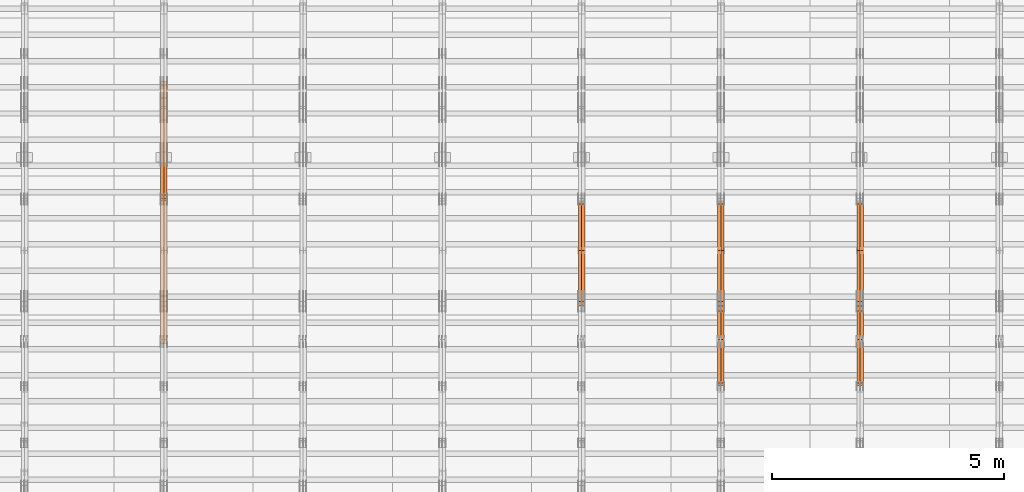
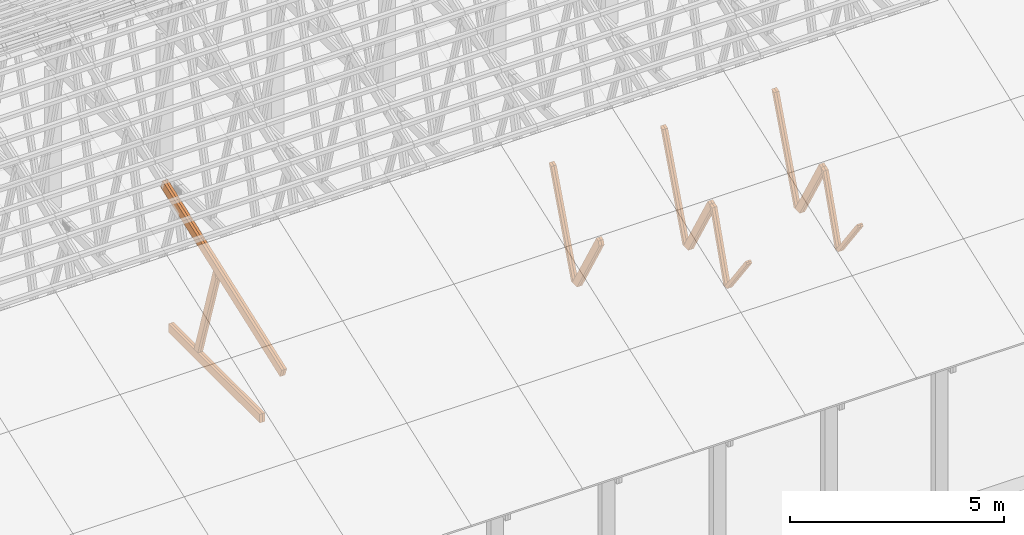
# One storey, part 24 of 189: 26 proxies.
"""IFC2X3 building model written with IfcOpenShell, lengths in millimetres."""

from ifc_helpers import new_model, entity, si_unit, converted_unit, derived_unit, direction, frame, origin, origin_2d_with_axis, place, context, subcontext, project, spatial, polyline, rectangle, outline, extrude, source, transform, mapped, material, type_object, type_shapes, element, save


model = new_model("IFC2X3")

# Units and contexts
model_context = context("Model", 3, precision=0.01, world=origin(), true_north=direction((6.12303176911189e-17, 1.0)))
body_context = subcontext(model_context, "Body", "Model", "MODEL_VIEW")
ifc_project = project(units=[si_unit("LENGTHUNIT", "METRE", prefix="MILLI"), si_unit("AREAUNIT", "SQUARE_METRE"), si_unit("VOLUMEUNIT", "CUBIC_METRE"), converted_unit("PLANEANGLEUNIT", "DEGREE", entity("IfcRatioMeasure", 0.0174532925199433), si_unit("PLANEANGLEUNIT", "RADIAN"), dimensions=[0, 0, 0, 0, 0, 0, 0]), si_unit("MASSUNIT", "GRAM", prefix="KILO"), derived_unit("MASSDENSITYUNIT", [(si_unit("MASSUNIT", "GRAM", prefix="KILO"), 1), (si_unit("LENGTHUNIT", "METRE"), -3)]), si_unit("TIMEUNIT", "SECOND"), si_unit("FREQUENCYUNIT", "HERTZ"), si_unit("THERMODYNAMICTEMPERATUREUNIT", "DEGREE_CELSIUS"), derived_unit("THERMALTRANSMITTANCEUNIT", [(si_unit("MASSUNIT", "GRAM", prefix="KILO"), 1), (si_unit("THERMODYNAMICTEMPERATUREUNIT", "KELVIN"), -1), (si_unit("TIMEUNIT", "SECOND"), -3)]), derived_unit("VOLUMETRICFLOWRATEUNIT", [(si_unit("LENGTHUNIT", "METRE"), 3), (si_unit("TIMEUNIT", "SECOND"), -1)]), si_unit("ELECTRICCURRENTUNIT", "AMPERE"), si_unit("ELECTRICVOLTAGEUNIT", "VOLT"), si_unit("POWERUNIT", "WATT"), si_unit("FORCEUNIT", "NEWTON"), si_unit("ILLUMINANCEUNIT", "LUX"), si_unit("LUMINOUSFLUXUNIT", "LUMEN"), si_unit("LUMINOUSINTENSITYUNIT", "CANDELA"), derived_unit("USERDEFINED", [(si_unit("MASSUNIT", "GRAM", prefix="KILO"), -1), (si_unit("LENGTHUNIT", "METRE"), -2), (si_unit("TIMEUNIT", "SECOND"), 3), (si_unit("LUMINOUSFLUXUNIT", "LUMEN"), 1)]), derived_unit("LINEARVELOCITYUNIT", [(si_unit("LENGTHUNIT", "METRE"), 1), (si_unit("TIMEUNIT", "SECOND"), -1)]), si_unit("PRESSUREUNIT", "PASCAL"), derived_unit("USERDEFINED", [(si_unit("LENGTHUNIT", "METRE"), -2), (si_unit("MASSUNIT", "GRAM", prefix="KILO"), 1), (si_unit("TIMEUNIT", "SECOND"), -2)])], contexts=[model_context])

# Site, building, storey
site_placement = place(None, origin())
site = spatial("IfcSite", under=ifc_project, at=site_placement, CompositionType="ELEMENT")
building_placement = place(site_placement, origin())
building = spatial("IfcBuilding", under=site, at=building_placement, CompositionType="ELEMENT")
storey_placement = place(building_placement, origin())
storey = spatial("IfcBuildingStorey", under=building, at=storey_placement, Name="Default", CompositionType="ELEMENT", Elevation=0.0)

# Proxies
ifc_material_1 = material(Name="IfcSurfaceStyle #161790")
building_element_proxy_type_1 = type_object("IfcBuildingElementProxyType", Name="T1-W8 161788", PredefinedType="NOTDEFINED", material=ifc_material_1)
shared_shape_1 = source(origin(), body_context, "Body", "SweptSolid", [
    extrude(outline(polyline([(-1781.70529904483, -47.500320228718), (1161.65050357787, -47.5003202287179), (1179.56135870849, 0.000731866266039397), (1140.6022069428, 47.4998218997103), (-1700.10877018433, 47.5000866914596), (-1781.70529904483, -47.500320228718)])), frame((1179.56135870869, 47.5007236522113, 0.0), z_axis=(0.0, 0.0, 1.0), x_axis=(-1.0, 3.74658825645258e-07, 0.0)), (0.0, 0.0, 1.0), 69.9999999999998),
])
type_shapes(building_element_proxy_type_1, [shared_shape_1])
proxy_1_placement = place(building_placement, frame((30300.0, 6723.5697965901, 261.758864533503), z_axis=(-1.0, 0.0, 0.0), x_axis=(0.0, 0.352814979177603, 0.93569310698963)))
element("IfcBuildingElementProxy", 1, at=proxy_1_placement, inside=storey, type_object=building_element_proxy_type_1, material=ifc_material_1, Name="T1-W8", context=body_context, shape_type="MappedRepresentation", body=[
    mapped(shared_shape_1, transform((0.0, 0.0, 0.0), scale=1.0)),
])
ifc_material_2 = material(Name="IfcSurfaceStyle #161724")
building_element_proxy_type_2 = type_object("IfcBuildingElementProxyType", Name="T1-W8 161722", PredefinedType="NOTDEFINED", material=ifc_material_2)
shared_shape_2 = source(origin(), body_context, "Body", "SweptSolid", [
    extrude(outline(polyline([(-1781.70529904483, -47.500320228718), (1161.65050357787, -47.5003202287179), (1179.56135870849, 0.000731866266039397), (1140.6022069428, 47.4998218997103), (-1700.10877018433, 47.5000866914596), (-1781.70529904483, -47.500320228718)])), frame((1179.56135870869, 47.5007236522113, 0.0), z_axis=(0.0, 0.0, 1.0), x_axis=(-1.0, 3.74658825645258e-07, 0.0)), (0.0, 0.0, 1.0), 69.9999999999998),
])
type_shapes(building_element_proxy_type_2, [shared_shape_2])
proxy_2_placement = place(building_placement, frame((30230.0, 6723.5697965901, 261.758864533503), z_axis=(-1.0, 0.0, 0.0), x_axis=(0.0, 0.352814979177603, 0.93569310698963)))
element("IfcBuildingElementProxy", 2, at=proxy_2_placement, inside=storey, type_object=building_element_proxy_type_2, material=ifc_material_2, Name="T1-W8", context=body_context, shape_type="MappedRepresentation", body=[
    mapped(shared_shape_2, transform((0.0, 0.0, 0.0), scale=1.0)),
])
ifc_material_3 = material(Name="IfcSurfaceStyle #161526")
building_element_proxy_type_3 = type_object("IfcBuildingElementProxyType", Name="T1-W2 161524", PredefinedType="NOTDEFINED", material=ifc_material_3)
shared_shape_3 = source(origin(), body_context, "Body", "SweptSolid", [
    extrude(outline(polyline([(-765.033104991319, -1130.91940266317), (-539.905732758898, -1130.91940266317), (493.678280567457, 660.584515081422), (452.144945212405, 783.697385511457), (359.115611970356, 817.556904733455), (-765.033104991319, -1130.91940266317)])), frame((904.774360566371, 97.5002668805543, 0.0), z_axis=(0.0, 0.0, 1.0), x_axis=(-0.499731715721184, 0.866180242387438, 0.0)), (0.0, 0.0, 1.0), 69.9999999999998),
])
type_shapes(building_element_proxy_type_3, [shared_shape_3])
proxy_3_placement = place(building_placement, frame((30300.0, 5635.28919163287, 2208.3400784451), z_axis=(-1.0, 0.0, 0.0), x_axis=(0.0, 0.5, -0.866025403784439)))
element("IfcBuildingElementProxy", 3, at=proxy_3_placement, inside=storey, type_object=building_element_proxy_type_3, material=ifc_material_3, Name="T1-W2", context=body_context, shape_type="MappedRepresentation", body=[
    mapped(shared_shape_3, transform((0.0, 0.0, 0.0), scale=1.0)),
])
ifc_material_4 = material(Name="IfcSurfaceStyle #161460")
building_element_proxy_type_4 = type_object("IfcBuildingElementProxyType", Name="T1-W2 161458", PredefinedType="NOTDEFINED", material=ifc_material_4)
shared_shape_4 = source(origin(), body_context, "Body", "SweptSolid", [
    extrude(outline(polyline([(-765.033104991319, -1130.91940266317), (-539.905732758898, -1130.91940266317), (493.678280567457, 660.584515081422), (452.144945212405, 783.697385511457), (359.115611970356, 817.556904733455), (-765.033104991319, -1130.91940266317)])), frame((904.774360566371, 97.5002668805543, 0.0), z_axis=(0.0, 0.0, 1.0), x_axis=(-0.499731715721184, 0.866180242387438, 0.0)), (0.0, 0.0, 1.0), 69.9999999999998),
])
type_shapes(building_element_proxy_type_4, [shared_shape_4])
proxy_4_placement = place(building_placement, frame((30230.0, 5635.28919163287, 2208.3400784451), z_axis=(-1.0, 0.0, 0.0), x_axis=(0.0, 0.5, -0.866025403784439)))
element("IfcBuildingElementProxy", 4, at=proxy_4_placement, inside=storey, type_object=building_element_proxy_type_4, material=ifc_material_4, Name="T1-W2", context=body_context, shape_type="MappedRepresentation", body=[
    mapped(shared_shape_4, transform((0.0, 0.0, 0.0), scale=1.0)),
])
ifc_material_5 = material(Name="IfcSurfaceStyle #161262")
building_element_proxy_type_5 = type_object("IfcBuildingElementProxyType", Name="T1-W9 161260", PredefinedType="NOTDEFINED", material=ifc_material_5)
shared_shape_5 = source(origin(), body_context, "Body", "SweptSolid", [
    extrude(outline(polyline([(-1227.3969292634, -47.5000382896404), (793.242467803064, -47.5000382896404), (809.267705296822, 1.0956605530188e-05), (776.329919980315, 47.5000328113376), (-1151.4431638168, 47.5000328113376), (-1227.3969292634, -47.5000382896404)])), frame((809.267705296822, 47.5000328113376, 0.0), z_axis=(0.0, 0.0, 1.0), x_axis=(-1.0, 0.0, 0.0)), (0.0, 0.0, 1.0), 69.9999999999999),
])
type_shapes(building_element_proxy_type_5, [shared_shape_5])
proxy_5_placement = place(building_placement, frame((30300.0, 4809.76380889125, 260.184242613649), z_axis=(-1.0, 0.0, 0.0), x_axis=(0.0, 0.31966811847134, 0.947529574226047)))
element("IfcBuildingElementProxy", 5, at=proxy_5_placement, inside=storey, type_object=building_element_proxy_type_5, material=ifc_material_5, Name="T1-W9", context=body_context, shape_type="MappedRepresentation", body=[
    mapped(shared_shape_5, transform((0.0, 0.0, 0.0), scale=1.0)),
])
ifc_material_6 = material(Name="IfcSurfaceStyle #161196")
building_element_proxy_type_6 = type_object("IfcBuildingElementProxyType", Name="T1-W9 161194", PredefinedType="NOTDEFINED", material=ifc_material_6)
shared_shape_6 = source(origin(), body_context, "Body", "SweptSolid", [
    extrude(outline(polyline([(-1227.3969292634, -47.5000382896404), (793.242467803064, -47.5000382896404), (809.267705296822, 1.0956605530188e-05), (776.329919980315, 47.5000328113376), (-1151.4431638168, 47.5000328113376), (-1227.3969292634, -47.5000382896404)])), frame((809.267705296822, 47.5000328113376, 0.0), z_axis=(0.0, 0.0, 1.0), x_axis=(-1.0, 0.0, 0.0)), (0.0, 0.0, 1.0), 69.9999999999999),
])
type_shapes(building_element_proxy_type_6, [shared_shape_6])
proxy_6_placement = place(building_placement, frame((30230.0, 4809.76380889125, 260.184242613649), z_axis=(-1.0, 0.0, 0.0), x_axis=(0.0, 0.31966811847134, 0.947529574226047)))
element("IfcBuildingElementProxy", 6, at=proxy_6_placement, inside=storey, type_object=building_element_proxy_type_6, material=ifc_material_6, Name="T1-W9", context=body_context, shape_type="MappedRepresentation", body=[
    mapped(shared_shape_6, transform((0.0, 0.0, 0.0), scale=1.0)),
])
ifc_material_7 = material(Name="IfcSurfaceStyle #160998")
building_element_proxy_type_7 = type_object("IfcBuildingElementProxyType", Name="T1-W10 160996", PredefinedType="NOTDEFINED", material=ifc_material_7)
shared_shape_7 = source(origin(), body_context, "Body", "SweptSolid", [
    extrude(outline(polyline([(-922.639472665691, -47.5001890573134), (629.920966338637, -47.5001890573134), (650.067737483374, 0.000694680531158376), (635.89112756682, 47.4998417170478), (-993.240358723139, 47.4998417170478), (-922.639472665691, -47.5001890573134)])), frame((650.068202545693, 47.4999816623145, 0.0), z_axis=(0.0, 0.0, 1.0), x_axis=(-1.0, 0.0, 0.0)), (0.0, 0.0, 1.0), 69.9999999999999),
])
type_shapes(building_element_proxy_type_7, [shared_shape_7])
proxy_7_placement = place(building_placement, frame((30300.0, 3874.56126239818, 1563.95828147518), z_axis=(-1.0, 0.0, 0.0), x_axis=(0.0, 0.596486092002, -0.802623412347398)))
element("IfcBuildingElementProxy", 7, at=proxy_7_placement, inside=storey, type_object=building_element_proxy_type_7, material=ifc_material_7, Name="T1-W10", context=body_context, shape_type="MappedRepresentation", body=[
    mapped(shared_shape_7, transform((0.0, 0.0, 0.0), scale=1.0)),
])
ifc_material_8 = material(Name="IfcSurfaceStyle #160932")
building_element_proxy_type_8 = type_object("IfcBuildingElementProxyType", Name="T1-W10 160930", PredefinedType="NOTDEFINED", material=ifc_material_8)
shared_shape_8 = source(origin(), body_context, "Body", "SweptSolid", [
    extrude(outline(polyline([(-922.639472665691, -47.5001890573134), (629.920966338637, -47.5001890573134), (650.067737483374, 0.000694680531158376), (635.89112756682, 47.4998417170478), (-993.240358723139, 47.4998417170478), (-922.639472665691, -47.5001890573134)])), frame((650.068202545693, 47.4999816623145, 0.0), z_axis=(0.0, 0.0, 1.0), x_axis=(-1.0, 0.0, 0.0)), (0.0, 0.0, 1.0), 69.9999999999999),
])
type_shapes(building_element_proxy_type_8, [shared_shape_8])
proxy_8_placement = place(building_placement, frame((30230.0, 3874.56126239818, 1563.95828147518), z_axis=(-1.0, 0.0, 0.0), x_axis=(0.0, 0.596486092002, -0.802623412347398)))
element("IfcBuildingElementProxy", 8, at=proxy_8_placement, inside=storey, type_object=building_element_proxy_type_8, material=ifc_material_8, Name="T1-W10", context=body_context, shape_type="MappedRepresentation", body=[
    mapped(shared_shape_8, transform((0.0, 0.0, 0.0), scale=1.0)),
])
ifc_material_9 = material(Name="IfcSurfaceStyle #146000")
building_element_proxy_type_9 = type_object("IfcBuildingElementProxyType", Name="T1-W8 145998", PredefinedType="NOTDEFINED", material=ifc_material_9)
shared_shape_9 = source(origin(), body_context, "Body", "SweptSolid", [
    extrude(outline(polyline([(-1781.70529904483, -47.500320228718), (1161.65050357787, -47.5003202287179), (1179.56135870849, 0.000731866266039397), (1140.6022069428, 47.4998218997103), (-1700.10877018433, 47.5000866914596), (-1781.70529904483, -47.500320228718)])), frame((1179.56135870869, 47.5007236522113, 0.0), z_axis=(0.0, 0.0, 1.0), x_axis=(-1.0, 3.74658825645258e-07, 0.0)), (0.0, 0.0, 1.0), 69.9999999999998),
])
type_shapes(building_element_proxy_type_9, [shared_shape_9])
proxy_9_placement = place(building_placement, frame((27300.0, 6723.5697965901, 261.758864533503), z_axis=(-1.0, 0.0, 0.0), x_axis=(0.0, 0.352814979177603, 0.93569310698963)))
element("IfcBuildingElementProxy", 9, at=proxy_9_placement, inside=storey, type_object=building_element_proxy_type_9, material=ifc_material_9, Name="T1-W8", context=body_context, shape_type="MappedRepresentation", body=[
    mapped(shared_shape_9, transform((0.0, 0.0, 0.0), scale=1.0)),
])
ifc_material_10 = material(Name="IfcSurfaceStyle #145934")
building_element_proxy_type_10 = type_object("IfcBuildingElementProxyType", Name="T1-W8 145932", PredefinedType="NOTDEFINED", material=ifc_material_10)
shared_shape_10 = source(origin(), body_context, "Body", "SweptSolid", [
    extrude(outline(polyline([(-1781.70529904483, -47.500320228718), (1161.65050357787, -47.5003202287179), (1179.56135870849, 0.000731866266039397), (1140.6022069428, 47.4998218997103), (-1700.10877018433, 47.5000866914596), (-1781.70529904483, -47.500320228718)])), frame((1179.56135870869, 47.5007236522113, 0.0), z_axis=(0.0, 0.0, 1.0), x_axis=(-1.0, 3.74658825645258e-07, 0.0)), (0.0, 0.0, 1.0), 69.9999999999998),
])
type_shapes(building_element_proxy_type_10, [shared_shape_10])
proxy_10_placement = place(building_placement, frame((27230.0, 6723.5697965901, 261.758864533503), z_axis=(-1.0, 0.0, 0.0), x_axis=(0.0, 0.352814979177603, 0.93569310698963)))
element("IfcBuildingElementProxy", 10, at=proxy_10_placement, inside=storey, type_object=building_element_proxy_type_10, material=ifc_material_10, Name="T1-W8", context=body_context, shape_type="MappedRepresentation", body=[
    mapped(shared_shape_10, transform((0.0, 0.0, 0.0), scale=1.0)),
])
ifc_material_11 = material(Name="IfcSurfaceStyle #145736")
building_element_proxy_type_11 = type_object("IfcBuildingElementProxyType", Name="T1-W2 145734", PredefinedType="NOTDEFINED", material=ifc_material_11)
shared_shape_11 = source(origin(), body_context, "Body", "SweptSolid", [
    extrude(outline(polyline([(-765.033104991319, -1130.91940266317), (-539.905732758898, -1130.91940266317), (493.678280567457, 660.584515081422), (452.144945212405, 783.697385511457), (359.115611970356, 817.556904733455), (-765.033104991319, -1130.91940266317)])), frame((904.774360566371, 97.5002668805543, 0.0), z_axis=(0.0, 0.0, 1.0), x_axis=(-0.499731715721184, 0.866180242387438, 0.0)), (0.0, 0.0, 1.0), 69.9999999999998),
])
type_shapes(building_element_proxy_type_11, [shared_shape_11])
proxy_11_placement = place(building_placement, frame((27300.0, 5635.28919163287, 2208.3400784451), z_axis=(-1.0, 0.0, 0.0), x_axis=(0.0, 0.5, -0.866025403784439)))
element("IfcBuildingElementProxy", 11, at=proxy_11_placement, inside=storey, type_object=building_element_proxy_type_11, material=ifc_material_11, Name="T1-W2", context=body_context, shape_type="MappedRepresentation", body=[
    mapped(shared_shape_11, transform((0.0, 0.0, 0.0), scale=1.0)),
])
ifc_material_12 = material(Name="IfcSurfaceStyle #145670")
building_element_proxy_type_12 = type_object("IfcBuildingElementProxyType", Name="T1-W2 145668", PredefinedType="NOTDEFINED", material=ifc_material_12)
shared_shape_12 = source(origin(), body_context, "Body", "SweptSolid", [
    extrude(outline(polyline([(-765.033104991319, -1130.91940266317), (-539.905732758898, -1130.91940266317), (493.678280567457, 660.584515081422), (452.144945212405, 783.697385511457), (359.115611970356, 817.556904733455), (-765.033104991319, -1130.91940266317)])), frame((904.774360566371, 97.5002668805543, 0.0), z_axis=(0.0, 0.0, 1.0), x_axis=(-0.499731715721184, 0.866180242387438, 0.0)), (0.0, 0.0, 1.0), 69.9999999999998),
])
type_shapes(building_element_proxy_type_12, [shared_shape_12])
proxy_12_placement = place(building_placement, frame((27230.0, 5635.28919163287, 2208.3400784451), z_axis=(-1.0, 0.0, 0.0), x_axis=(0.0, 0.5, -0.866025403784439)))
element("IfcBuildingElementProxy", 12, at=proxy_12_placement, inside=storey, type_object=building_element_proxy_type_12, material=ifc_material_12, Name="T1-W2", context=body_context, shape_type="MappedRepresentation", body=[
    mapped(shared_shape_12, transform((0.0, 0.0, 0.0), scale=1.0)),
])
ifc_material_13 = material(Name="IfcSurfaceStyle #145472")
building_element_proxy_type_13 = type_object("IfcBuildingElementProxyType", Name="T1-W9 145470", PredefinedType="NOTDEFINED", material=ifc_material_13)
shared_shape_13 = source(origin(), body_context, "Body", "SweptSolid", [
    extrude(outline(polyline([(-1227.3969292634, -47.5000382896404), (793.242467803064, -47.5000382896404), (809.267705296822, 1.0956605530188e-05), (776.329919980315, 47.5000328113376), (-1151.4431638168, 47.5000328113376), (-1227.3969292634, -47.5000382896404)])), frame((809.267705296822, 47.5000328113376, 0.0), z_axis=(0.0, 0.0, 1.0), x_axis=(-1.0, 0.0, 0.0)), (0.0, 0.0, 1.0), 69.9999999999999),
])
type_shapes(building_element_proxy_type_13, [shared_shape_13])
proxy_13_placement = place(building_placement, frame((27300.0, 4809.76380889125, 260.184242613649), z_axis=(-1.0, 0.0, 0.0), x_axis=(0.0, 0.31966811847134, 0.947529574226047)))
element("IfcBuildingElementProxy", 13, at=proxy_13_placement, inside=storey, type_object=building_element_proxy_type_13, material=ifc_material_13, Name="T1-W9", context=body_context, shape_type="MappedRepresentation", body=[
    mapped(shared_shape_13, transform((0.0, 0.0, 0.0), scale=1.0)),
])
ifc_material_14 = material(Name="IfcSurfaceStyle #145406")
building_element_proxy_type_14 = type_object("IfcBuildingElementProxyType", Name="T1-W9 145404", PredefinedType="NOTDEFINED", material=ifc_material_14)
shared_shape_14 = source(origin(), body_context, "Body", "SweptSolid", [
    extrude(outline(polyline([(-1227.3969292634, -47.5000382896404), (793.242467803064, -47.5000382896404), (809.267705296822, 1.0956605530188e-05), (776.329919980315, 47.5000328113376), (-1151.4431638168, 47.5000328113376), (-1227.3969292634, -47.5000382896404)])), frame((809.267705296822, 47.5000328113376, 0.0), z_axis=(0.0, 0.0, 1.0), x_axis=(-1.0, 0.0, 0.0)), (0.0, 0.0, 1.0), 69.9999999999999),
])
type_shapes(building_element_proxy_type_14, [shared_shape_14])
proxy_14_placement = place(building_placement, frame((27230.0, 4809.76380889125, 260.184242613649), z_axis=(-1.0, 0.0, 0.0), x_axis=(0.0, 0.31966811847134, 0.947529574226047)))
element("IfcBuildingElementProxy", 14, at=proxy_14_placement, inside=storey, type_object=building_element_proxy_type_14, material=ifc_material_14, Name="T1-W9", context=body_context, shape_type="MappedRepresentation", body=[
    mapped(shared_shape_14, transform((0.0, 0.0, 0.0), scale=1.0)),
])
ifc_material_15 = material(Name="IfcSurfaceStyle #145208")
building_element_proxy_type_15 = type_object("IfcBuildingElementProxyType", Name="T1-W10 145206", PredefinedType="NOTDEFINED", material=ifc_material_15)
shared_shape_15 = source(origin(), body_context, "Body", "SweptSolid", [
    extrude(outline(polyline([(-922.639472665691, -47.5001890573134), (629.920966338637, -47.5001890573134), (650.067737483374, 0.000694680531158376), (635.89112756682, 47.4998417170478), (-993.240358723139, 47.4998417170478), (-922.639472665691, -47.5001890573134)])), frame((650.068202545693, 47.4999816623145, 0.0), z_axis=(0.0, 0.0, 1.0), x_axis=(-1.0, 0.0, 0.0)), (0.0, 0.0, 1.0), 69.9999999999999),
])
type_shapes(building_element_proxy_type_15, [shared_shape_15])
proxy_15_placement = place(building_placement, frame((27300.0, 3874.56126239818, 1563.95828147518), z_axis=(-1.0, 0.0, 0.0), x_axis=(0.0, 0.596486092002, -0.802623412347398)))
element("IfcBuildingElementProxy", 15, at=proxy_15_placement, inside=storey, type_object=building_element_proxy_type_15, material=ifc_material_15, Name="T1-W10", context=body_context, shape_type="MappedRepresentation", body=[
    mapped(shared_shape_15, transform((0.0, 0.0, 0.0), scale=1.0)),
])
ifc_material_16 = material(Name="IfcSurfaceStyle #145142")
building_element_proxy_type_16 = type_object("IfcBuildingElementProxyType", Name="T1-W10 145140", PredefinedType="NOTDEFINED", material=ifc_material_16)
shared_shape_16 = source(origin(), body_context, "Body", "SweptSolid", [
    extrude(outline(polyline([(-922.639472665691, -47.5001890573134), (629.920966338637, -47.5001890573134), (650.067737483374, 0.000694680531158376), (635.89112756682, 47.4998417170478), (-993.240358723139, 47.4998417170478), (-922.639472665691, -47.5001890573134)])), frame((650.068202545693, 47.4999816623145, 0.0), z_axis=(0.0, 0.0, 1.0), x_axis=(-1.0, 0.0, 0.0)), (0.0, 0.0, 1.0), 69.9999999999999),
])
type_shapes(building_element_proxy_type_16, [shared_shape_16])
proxy_16_placement = place(building_placement, frame((27230.0, 3874.56126239818, 1563.95828147518), z_axis=(-1.0, 0.0, 0.0), x_axis=(0.0, 0.596486092002, -0.802623412347398)))
element("IfcBuildingElementProxy", 16, at=proxy_16_placement, inside=storey, type_object=building_element_proxy_type_16, material=ifc_material_16, Name="T1-W10", context=body_context, shape_type="MappedRepresentation", body=[
    mapped(shared_shape_16, transform((0.0, 0.0, 0.0), scale=1.0)),
])
ifc_material_17 = material(Name="IfcSurfaceStyle #130210")
building_element_proxy_type_17 = type_object("IfcBuildingElementProxyType", Name="T1-W8 130208", PredefinedType="NOTDEFINED", material=ifc_material_17)
shared_shape_17 = source(origin(), body_context, "Body", "SweptSolid", [
    extrude(outline(polyline([(-1781.70529904483, -47.500320228718), (1161.65050357787, -47.5003202287179), (1179.56135870849, 0.000731866266039397), (1140.6022069428, 47.4998218997103), (-1700.10877018433, 47.5000866914596), (-1781.70529904483, -47.500320228718)])), frame((1179.56135870869, 47.5007236522113, 0.0), z_axis=(0.0, 0.0, 1.0), x_axis=(-1.0, 3.74658825645258e-07, 0.0)), (0.0, 0.0, 1.0), 69.9999999999998),
])
type_shapes(building_element_proxy_type_17, [shared_shape_17])
proxy_17_placement = place(building_placement, frame((24300.0, 6723.5697965901, 261.758864533503), z_axis=(-1.0, 0.0, 0.0), x_axis=(0.0, 0.352814979177603, 0.93569310698963)))
element("IfcBuildingElementProxy", 17, at=proxy_17_placement, inside=storey, type_object=building_element_proxy_type_17, material=ifc_material_17, Name="T1-W8", context=body_context, shape_type="MappedRepresentation", body=[
    mapped(shared_shape_17, transform((0.0, 0.0, 0.0), scale=1.0)),
])
ifc_material_18 = material(Name="IfcSurfaceStyle #130144")
building_element_proxy_type_18 = type_object("IfcBuildingElementProxyType", Name="T1-W8 130142", PredefinedType="NOTDEFINED", material=ifc_material_18)
shared_shape_18 = source(origin(), body_context, "Body", "SweptSolid", [
    extrude(outline(polyline([(-1781.70529904483, -47.500320228718), (1161.65050357787, -47.5003202287179), (1179.56135870849, 0.000731866266039397), (1140.6022069428, 47.4998218997103), (-1700.10877018433, 47.5000866914596), (-1781.70529904483, -47.500320228718)])), frame((1179.56135870869, 47.5007236522113, 0.0), z_axis=(0.0, 0.0, 1.0), x_axis=(-1.0, 3.74658825645258e-07, 0.0)), (0.0, 0.0, 1.0), 69.9999999999998),
])
type_shapes(building_element_proxy_type_18, [shared_shape_18])
proxy_18_placement = place(building_placement, frame((24230.0, 6723.5697965901, 261.758864533503), z_axis=(-1.0, 0.0, 0.0), x_axis=(0.0, 0.352814979177603, 0.93569310698963)))
element("IfcBuildingElementProxy", 18, at=proxy_18_placement, inside=storey, type_object=building_element_proxy_type_18, material=ifc_material_18, Name="T1-W8", context=body_context, shape_type="MappedRepresentation", body=[
    mapped(shared_shape_18, transform((0.0, 0.0, 0.0), scale=1.0)),
])
ifc_material_19 = material(Name="IfcSurfaceStyle #129946")
building_element_proxy_type_19 = type_object("IfcBuildingElementProxyType", Name="T1-W2 129944", PredefinedType="NOTDEFINED", material=ifc_material_19)
shared_shape_19 = source(origin(), body_context, "Body", "SweptSolid", [
    extrude(outline(polyline([(-765.033104991319, -1130.91940266317), (-539.905732758898, -1130.91940266317), (493.678280567457, 660.584515081422), (452.144945212405, 783.697385511457), (359.115611970356, 817.556904733455), (-765.033104991319, -1130.91940266317)])), frame((904.774360566371, 97.5002668805543, 0.0), z_axis=(0.0, 0.0, 1.0), x_axis=(-0.499731715721184, 0.866180242387438, 0.0)), (0.0, 0.0, 1.0), 69.9999999999998),
])
type_shapes(building_element_proxy_type_19, [shared_shape_19])
proxy_19_placement = place(building_placement, frame((24300.0, 5635.28919163287, 2208.3400784451), z_axis=(-1.0, 0.0, 0.0), x_axis=(0.0, 0.5, -0.866025403784439)))
element("IfcBuildingElementProxy", 19, at=proxy_19_placement, inside=storey, type_object=building_element_proxy_type_19, material=ifc_material_19, Name="T1-W2", context=body_context, shape_type="MappedRepresentation", body=[
    mapped(shared_shape_19, transform((0.0, 0.0, 0.0), scale=1.0)),
])
ifc_material_20 = material(Name="IfcSurfaceStyle #129880")
building_element_proxy_type_20 = type_object("IfcBuildingElementProxyType", Name="T1-W2 129878", PredefinedType="NOTDEFINED", material=ifc_material_20)
shared_shape_20 = source(origin(), body_context, "Body", "SweptSolid", [
    extrude(outline(polyline([(-765.033104991319, -1130.91940266317), (-539.905732758898, -1130.91940266317), (493.678280567457, 660.584515081422), (452.144945212405, 783.697385511457), (359.115611970356, 817.556904733455), (-765.033104991319, -1130.91940266317)])), frame((904.774360566371, 97.5002668805543, 0.0), z_axis=(0.0, 0.0, 1.0), x_axis=(-0.499731715721184, 0.866180242387438, 0.0)), (0.0, 0.0, 1.0), 69.9999999999998),
])
type_shapes(building_element_proxy_type_20, [shared_shape_20])
proxy_20_placement = place(building_placement, frame((24230.0, 5635.28919163287, 2208.3400784451), z_axis=(-1.0, 0.0, 0.0), x_axis=(0.0, 0.5, -0.866025403784439)))
element("IfcBuildingElementProxy", 20, at=proxy_20_placement, inside=storey, type_object=building_element_proxy_type_20, material=ifc_material_20, Name="T1-W2", context=body_context, shape_type="MappedRepresentation", body=[
    mapped(shared_shape_20, transform((0.0, 0.0, 0.0), scale=1.0)),
])
ifc_material_21 = material(Name="IfcSurfaceStyle #83104")
building_element_proxy_type_21 = type_object("IfcBuildingElementProxyType", Name="T1-W4 83102", PredefinedType="NOTDEFINED", material=ifc_material_21)
shared_shape_21 = source(origin(), body_context, "Body", "SweptSolid", [
    extrude(outline(polyline([(-1688.09292256655, -85.0003489723785), (1071.44998120742, -85.0003489723785), (1178.19407811536, -0.00016040063201781), (1181.35435681367, 85.0004291726946), (-1742.9054935699, 85.0004291726946), (-1688.09292256655, -85.0003489723785)])), frame((1181.35446122976, 85.0007670757732, 0.0), z_axis=(0.0, 0.0, 1.0), x_axis=(-1.0, 0.0, 0.0)), (0.0, 0.0, 1.0), 69.9999999999998),
])
type_shapes(building_element_proxy_type_21, [shared_shape_21])
proxy_21_placement = place(building_placement, frame((15300.0, 7937.17021143291, 3028.170124945), z_axis=(-1.0, 0.0, 0.0), x_axis=(0.0, 0.306868406216492, -0.951751953644514)))
element("IfcBuildingElementProxy", 21, at=proxy_21_placement, inside=storey, type_object=building_element_proxy_type_21, material=ifc_material_21, Name="T1-W4", context=body_context, shape_type="MappedRepresentation", body=[
    mapped(shared_shape_21, transform((0.0, 0.0, 0.0), scale=1.0)),
])
ifc_material_22 = material(Name="IfcSurfaceStyle #83038")
building_element_proxy_type_22 = type_object("IfcBuildingElementProxyType", Name="T1-W4 83036", PredefinedType="NOTDEFINED", material=ifc_material_22)
shared_shape_22 = source(origin(), body_context, "Body", "SweptSolid", [
    extrude(outline(polyline([(-1688.09292256655, -85.0003489723785), (1071.44998120742, -85.0003489723785), (1178.19407811536, -0.00016040063201781), (1181.35435681367, 85.0004291726946), (-1742.9054935699, 85.0004291726946), (-1688.09292256655, -85.0003489723785)])), frame((1181.35446122976, 85.0007670757732, 0.0), z_axis=(0.0, 0.0, 1.0), x_axis=(-1.0, 0.0, 0.0)), (0.0, 0.0, 1.0), 69.9999999999998),
])
type_shapes(building_element_proxy_type_22, [shared_shape_22])
proxy_22_placement = place(building_placement, frame((15230.0, 7937.17021143291, 3028.170124945), z_axis=(-1.0, 0.0, 0.0), x_axis=(0.0, 0.306868406216492, -0.951751953644514)))
element("IfcBuildingElementProxy", 22, at=proxy_22_placement, inside=storey, type_object=building_element_proxy_type_22, material=ifc_material_22, Name="T1-W4", context=body_context, shape_type="MappedRepresentation", body=[
    mapped(shared_shape_22, transform((0.0, 0.0, 0.0), scale=1.0)),
])
ifc_material_23 = material(Name="IfcSurfaceStyle #80026")
building_element_proxy_type_23 = type_object("IfcBuildingElementProxyType", Name="T1-B6 80024", PredefinedType="NOTDEFINED", material=ifc_material_23)
shared_shape_23 = source(origin(), body_context, "Body", "SweptSolid", [
    extrude(rectangle(XDim=4266.763671875, YDim=245.000000000001, at=origin_2d_with_axis()), frame((2133.3818359375, 122.500000000001, 0.0), z_axis=(0.0, 0.0, 1.0), x_axis=(-1.0, 0.0, 0.0)), (0.0, 0.0, 1.0), 69.9999999999997),
])
type_shapes(building_element_proxy_type_23, [shared_shape_23])
proxy_23_placement = place(building_placement, frame((15300.0, 5762.466796875, 245.0), z_axis=(-1.0, 0.0, 0.0), x_axis=(0.0, 1.0, 0.0)))
element("IfcBuildingElementProxy", 23, at=proxy_23_placement, inside=storey, type_object=building_element_proxy_type_23, material=ifc_material_23, Name="T1-B6", context=body_context, shape_type="MappedRepresentation", body=[
    mapped(shared_shape_23, transform((0.0, 0.0, 0.0), scale=1.0)),
])
ifc_material_24 = material(Name="IfcSurfaceStyle #79969")
building_element_proxy_type_24 = type_object("IfcBuildingElementProxyType", Name="T1-B6 79967", PredefinedType="NOTDEFINED", material=ifc_material_24)
shared_shape_24 = source(origin(), body_context, "Body", "SweptSolid", [
    extrude(rectangle(XDim=4266.763671875, YDim=245.000000000001, at=origin_2d_with_axis()), frame((2133.3818359375, 122.500000000001, 0.0), z_axis=(0.0, 0.0, 1.0), x_axis=(-1.0, 0.0, 0.0)), (0.0, 0.0, 1.0), 69.9999999999997),
])
type_shapes(building_element_proxy_type_24, [shared_shape_24])
proxy_24_placement = place(building_placement, frame((15230.0, 5762.466796875, 245.0), z_axis=(-1.0, 0.0, 0.0), x_axis=(0.0, 1.0, 0.0)))
element("IfcBuildingElementProxy", 24, at=proxy_24_placement, inside=storey, type_object=building_element_proxy_type_24, material=ifc_material_24, Name="T1-B6", context=body_context, shape_type="MappedRepresentation", body=[
    mapped(shared_shape_24, transform((0.0, 0.0, 0.0), scale=1.0)),
])
ifc_material_25 = material(Name="IfcSurfaceStyle #79666")
building_element_proxy_type_25 = type_object("IfcBuildingElementProxyType", Name="T1-T1 79664", PredefinedType="NOTDEFINED", material=ifc_material_25)
shared_shape_25 = source(origin(), body_context, "Body", "SweptSolid", [
    extrude(outline(polyline([(-2964.99981923522, -122.500027388895), (2964.99982426074, -122.500027388895), (2964.99984011048, 122.500027388895), (-2964.99984513599, 122.500027388895), (-2964.99981923522, -122.500027388895)])), frame((2965.00021857317, 122.500056320695, 0.0), z_axis=(0.0, 0.0, 1.0), x_axis=(-1.0, 0.0, 0.0)), (0.0, 0.0, 1.0), 69.9999999999996),
])
type_shapes(building_element_proxy_type_25, [shared_shape_25])
proxy_25_placement = place(building_placement, frame((15300.0, 10391.0374749089, 3921.30478975487), z_axis=(-1.0, 0.0, 0.0), x_axis=(0.0, -0.939692620785908, -0.342020143325669)))
element("IfcBuildingElementProxy", 25, at=proxy_25_placement, inside=storey, type_object=building_element_proxy_type_25, material=ifc_material_25, Name="T1-T1", context=body_context, shape_type="MappedRepresentation", body=[
    mapped(shared_shape_25, transform((0.0, 0.0, 0.0), scale=1.0)),
])
ifc_material_26 = material(Name="IfcSurfaceStyle #79609")
building_element_proxy_type_26 = type_object("IfcBuildingElementProxyType", Name="T1-T1 79607", PredefinedType="NOTDEFINED", material=ifc_material_26)
shared_shape_26 = source(origin(), body_context, "Body", "SweptSolid", [
    extrude(outline(polyline([(-2964.99981923522, -122.500027388895), (2964.99982426074, -122.500027388895), (2964.99984011048, 122.500027388895), (-2964.99984513599, 122.500027388895), (-2964.99981923522, -122.500027388895)])), frame((2965.00021857317, 122.500056320695, 0.0), z_axis=(0.0, 0.0, 1.0), x_axis=(-1.0, 0.0, 0.0)), (0.0, 0.0, 1.0), 69.9999999999996),
])
type_shapes(building_element_proxy_type_26, [shared_shape_26])
proxy_26_placement = place(building_placement, frame((15230.0, 10391.0374749089, 3921.30478975487), z_axis=(-1.0, 0.0, 0.0), x_axis=(0.0, -0.939692620785908, -0.342020143325669)))
element("IfcBuildingElementProxy", 26, at=proxy_26_placement, inside=storey, type_object=building_element_proxy_type_26, material=ifc_material_26, Name="T1-T1", context=body_context, shape_type="MappedRepresentation", body=[
    mapped(shared_shape_26, transform((0.0, 0.0, 0.0), scale=1.0)),
])

save(model, "model.ifc")
